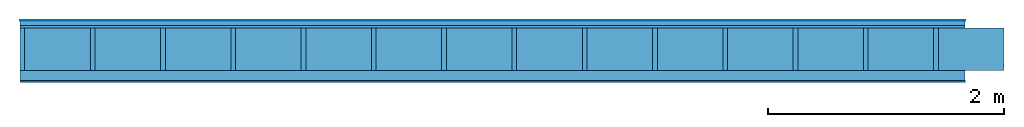
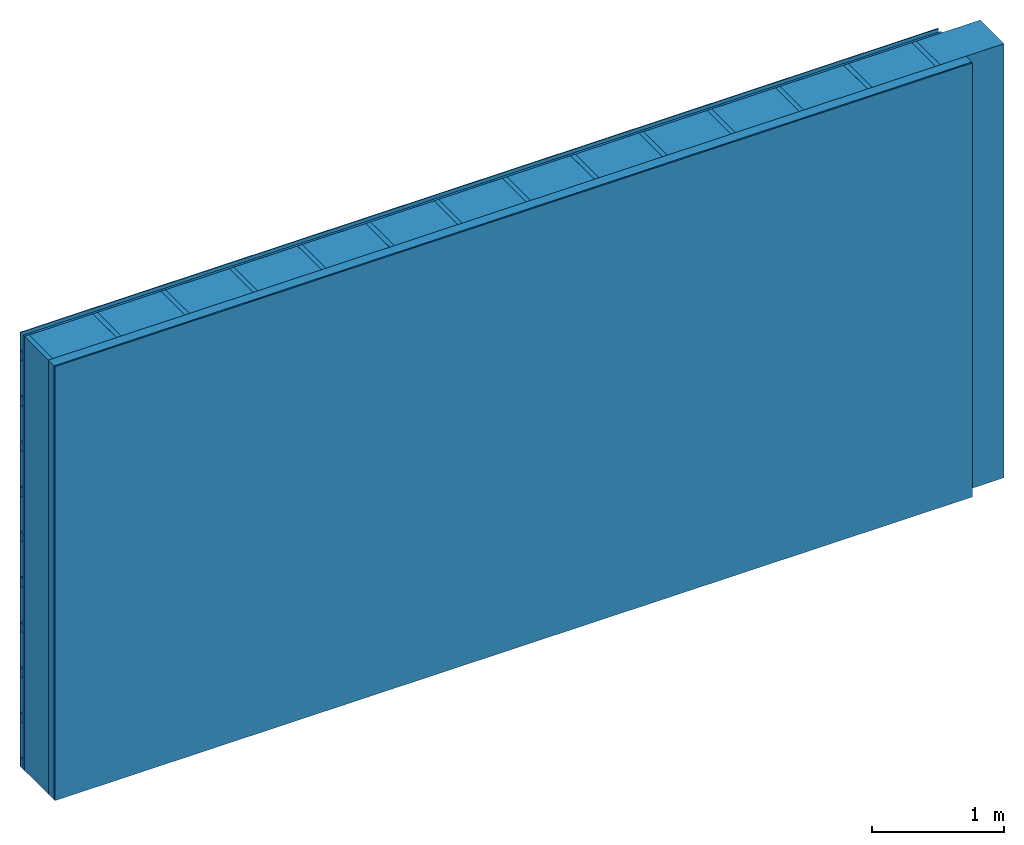
# One storey: 4 plates, 3 members, 1 element without a shape of its own.
"""IFC4 building model written with IfcOpenShell, lengths in metres."""

from ifc_helpers import new_model, si_unit, derived_unit, direction, frame, frame_2d, origin, origin_with_axes, place, context, project, spatial, rectangle, extrude, material, layer, layer_set, type_object, element, aggregate, save


model = new_model("IFC4")

# Units and contexts
plan_context = context("Plan", 3, precision=1e-05, world=origin(), true_north=direction((0.0, 1.0)))
model_context = context("Model", 3, precision=1e-05, world=origin(), true_north=direction((0.0, 1.0)))
ifc_project = project(units=[si_unit("LENGTHUNIT", "METRE"), derived_unit("SOUNDPRESSUREUNIT", [(si_unit("PRESSUREUNIT", "PASCAL", prefix="MICRO"), 0)]), si_unit("ENERGYUNIT", "JOULE", prefix="MEGA"), si_unit("MASSUNIT", "GRAM", prefix="KILO"), derived_unit("THERMALTRANSMITTANCEUNIT", [(si_unit("POWERUNIT", "WATT"), 1), (si_unit("AREAUNIT", "SQUARE_METRE"), -1), (si_unit("THERMODYNAMICTEMPERATUREUNIT", "KELVIN"), -1)]), derived_unit("AREADENSITYUNIT", [(si_unit("MASSUNIT", "GRAM", prefix="KILO"), 1), (si_unit("AREAUNIT", "SQUARE_METRE"), -1)]), derived_unit("USERDEFINED", [(si_unit("ENERGYUNIT", "JOULE", prefix="MEGA"), 1), (si_unit("AREAUNIT", "SQUARE_METRE"), -1)])], contexts=[plan_context, model_context])

# Site, building, storey
site = spatial("IfcSite", under=ifc_project)
building_placement = place(None, origin())
building = spatial("IfcBuilding", under=site, at=building_placement)
storey_placement = place(building_placement, origin())
storey = spatial("IfcBuildingStorey", under=building, at=storey_placement)

# Wall, members, plates
ifc_material_1 = material(Name="mineral, cement-based building board", Category="03.003")
ifc_layer_1 = layer(ifc_material_1, 0.008, Name="Cover 1st layer")
ifc_layer_2 = layer(None, 0.04, Name="Battens / profiles (ventilation)")
ifc_material_2 = material(Category="10.009")
ifc_layer_3 = layer(ifc_material_2, 0.02, Name="outside 1st layer")
ifc_material_3 = material(Name="of the art")
ifc_layer_4 = layer(ifc_material_3, 0.0, Name="Bond")
ifc_layer_5 = layer(None, 0.36, Name="Support")
ifc_layer_6 = layer(ifc_material_3, 0.0, Name="Bond")
ifc_material_4 = material(Name="Solid timber panel")
ifc_layer_7 = layer(ifc_material_4, 0.087, Name="1st layer")
ifc_material_5 = material(Name="Plasterboard type A", Category="03.008")
ifc_layer_8 = layer(ifc_material_5, 0.0125, Name="Covering 1st layer")
ifc_material_6 = material(Name="joints", Category="04.017")
ifc_layer_9 = layer(ifc_material_6, 0.0, Name="Surface")
ifc_layer_set = layer_set([ifc_layer_1, ifc_layer_2, ifc_layer_3, ifc_layer_4, ifc_layer_5, ifc_layer_6, ifc_layer_7, ifc_layer_8, ifc_layer_9])
wall_type = type_object("IfcWallType", Name="D0973", PredefinedType="NOTDEFINED", material=ifc_layer_set)
wall_placement = place(None, frame((0.0, 0.0, 0.0), z_axis=(0.0, -1.0, 0.0), x_axis=(1.0, 0.0, 0.0)))
wall = element("IfcWall", 1, at=wall_placement, inside=storey, type_object=wall_type, material=ifc_layer_set, Name="Wall #1")
ifc_material_7 = material()
member_1_placement = place(wall_placement, origin())
member_1 = element("IfcMember", 2, at=member_1_placement, material=ifc_material_7, Name="Battens / profiles (ventilation)", context=plan_context, shape_type="SweptSolid", body=[
    extrude(rectangle(XDim=0.08, YDim=0.04, at=frame_2d((0.04, 0.02), x_axis=(1.0, 0.0))), frame((0.0, 0.0, 0.008), z_axis=(1.0, 0.0, 0.0), x_axis=(0.0, 1.0, 0.0)), (0.0, 0.0, 1.0), 8.0),
    extrude(rectangle(XDim=0.08, YDim=0.04, at=frame_2d((0.04, 0.02), x_axis=(1.0, 0.0))), frame((0.0, 0.417, 0.008), z_axis=(1.0, 0.0, 0.0), x_axis=(0.0, 1.0, 0.0)), (0.0, 0.0, 1.0), 8.0),
    extrude(rectangle(XDim=0.08, YDim=0.04, at=frame_2d((0.04, 0.02), x_axis=(1.0, 0.0))), frame((0.0, 0.834, 0.008), z_axis=(1.0, 0.0, 0.0), x_axis=(0.0, 1.0, 0.0)), (0.0, 0.0, 1.0), 8.0),
    extrude(rectangle(XDim=0.08, YDim=0.04, at=frame_2d((0.04, 0.02), x_axis=(1.0, 0.0))), frame((0.0, 1.251, 0.008), z_axis=(1.0, 0.0, 0.0), x_axis=(0.0, 1.0, 0.0)), (0.0, 0.0, 1.0), 8.0),
    extrude(rectangle(XDim=0.08, YDim=0.04, at=frame_2d((0.04, 0.02), x_axis=(1.0, 0.0))), frame((0.0, 1.668, 0.008), z_axis=(1.0, 0.0, 0.0), x_axis=(0.0, 1.0, 0.0)), (0.0, 0.0, 1.0), 8.0),
    extrude(rectangle(XDim=0.08, YDim=0.04, at=frame_2d((0.04, 0.02), x_axis=(1.0, 0.0))), frame((0.0, 2.085, 0.008), z_axis=(1.0, 0.0, 0.0), x_axis=(0.0, 1.0, 0.0)), (0.0, 0.0, 1.0), 8.0),
    extrude(rectangle(XDim=0.08, YDim=0.04, at=frame_2d((0.04, 0.02), x_axis=(1.0, 0.0))), frame((0.0, 2.502, 0.008), z_axis=(1.0, 0.0, 0.0), x_axis=(0.0, 1.0, 0.0)), (0.0, 0.0, 1.0), 8.0),
    extrude(rectangle(XDim=0.08, YDim=0.04, at=frame_2d((0.04, 0.02), x_axis=(1.0, 0.0))), frame((0.0, 2.919, 0.008), z_axis=(1.0, 0.0, 0.0), x_axis=(0.0, 1.0, 0.0)), (0.0, 0.0, 1.0), 8.0),
    extrude(rectangle(XDim=0.08, YDim=0.04, at=frame_2d((0.04, 0.02), x_axis=(1.0, 0.0))), frame((0.0, 3.336, 0.008), z_axis=(1.0, 0.0, 0.0), x_axis=(0.0, 1.0, 0.0)), (0.0, 0.0, 1.0), 8.0),
    extrude(rectangle(XDim=0.08, YDim=0.04, at=frame_2d((0.04, 0.02), x_axis=(1.0, 0.0))), frame((0.0, 3.753, 0.008), z_axis=(1.0, 0.0, 0.0), x_axis=(0.0, 1.0, 0.0)), (0.0, 0.0, 1.0), 8.0),
])
ifc_material_8 = material()
member_2_placement = place(wall_placement, origin())
member_2 = element("IfcMember", 3, at=member_2_placement, material=ifc_material_8, Name="Support", context=plan_context, shape_type="SweptSolid", body=[
    extrude(rectangle(XDim=0.04, YDim=0.36, at=frame_2d((0.02, 0.18), x_axis=(1.0, 0.0))), frame((0.0, 4.0, 0.068), z_axis=(0.0, -1.0, 0.0), x_axis=(1.0, 0.0, 0.0)), (0.0, 0.0, 1.0), 4.0),
    extrude(rectangle(XDim=0.04, YDim=0.36, at=frame_2d((0.02, 0.18), x_axis=(1.0, 0.0))), frame((0.595, 4.0, 0.068), z_axis=(0.0, -1.0, 0.0), x_axis=(1.0, 0.0, 0.0)), (0.0, 0.0, 1.0), 4.0),
    extrude(rectangle(XDim=0.04, YDim=0.36, at=frame_2d((0.02, 0.18), x_axis=(1.0, 0.0))), frame((1.19, 4.0, 0.068), z_axis=(0.0, -1.0, 0.0), x_axis=(1.0, 0.0, 0.0)), (0.0, 0.0, 1.0), 4.0),
    extrude(rectangle(XDim=0.04, YDim=0.36, at=frame_2d((0.02, 0.18), x_axis=(1.0, 0.0))), frame((1.785, 4.0, 0.068), z_axis=(0.0, -1.0, 0.0), x_axis=(1.0, 0.0, 0.0)), (0.0, 0.0, 1.0), 4.0),
    extrude(rectangle(XDim=0.04, YDim=0.36, at=frame_2d((0.02, 0.18), x_axis=(1.0, 0.0))), frame((2.38, 4.0, 0.068), z_axis=(0.0, -1.0, 0.0), x_axis=(1.0, 0.0, 0.0)), (0.0, 0.0, 1.0), 4.0),
    extrude(rectangle(XDim=0.04, YDim=0.36, at=frame_2d((0.02, 0.18), x_axis=(1.0, 0.0))), frame((2.975, 4.0, 0.068), z_axis=(0.0, -1.0, 0.0), x_axis=(1.0, 0.0, 0.0)), (0.0, 0.0, 1.0), 4.0),
    extrude(rectangle(XDim=0.04, YDim=0.36, at=frame_2d((0.02, 0.18), x_axis=(1.0, 0.0))), frame((3.57, 4.0, 0.068), z_axis=(0.0, -1.0, 0.0), x_axis=(1.0, 0.0, 0.0)), (0.0, 0.0, 1.0), 4.0),
    extrude(rectangle(XDim=0.04, YDim=0.36, at=frame_2d((0.02, 0.18), x_axis=(1.0, 0.0))), frame((4.165, 4.0, 0.068), z_axis=(0.0, -1.0, 0.0), x_axis=(1.0, 0.0, 0.0)), (0.0, 0.0, 1.0), 4.0),
    extrude(rectangle(XDim=0.04, YDim=0.36, at=frame_2d((0.02, 0.18), x_axis=(1.0, 0.0))), frame((4.76, 4.0, 0.068), z_axis=(0.0, -1.0, 0.0), x_axis=(1.0, 0.0, 0.0)), (0.0, 0.0, 1.0), 4.0),
    extrude(rectangle(XDim=0.04, YDim=0.36, at=frame_2d((0.02, 0.18), x_axis=(1.0, 0.0))), frame((5.355, 4.0, 0.068), z_axis=(0.0, -1.0, 0.0), x_axis=(1.0, 0.0, 0.0)), (0.0, 0.0, 1.0), 4.0),
    extrude(rectangle(XDim=0.04, YDim=0.36, at=frame_2d((0.02, 0.18), x_axis=(1.0, 0.0))), frame((5.95, 4.0, 0.068), z_axis=(0.0, -1.0, 0.0), x_axis=(1.0, 0.0, 0.0)), (0.0, 0.0, 1.0), 4.0),
    extrude(rectangle(XDim=0.04, YDim=0.36, at=frame_2d((0.02, 0.18), x_axis=(1.0, 0.0))), frame((6.545, 4.0, 0.068), z_axis=(0.0, -1.0, 0.0), x_axis=(1.0, 0.0, 0.0)), (0.0, 0.0, 1.0), 4.0),
    extrude(rectangle(XDim=0.04, YDim=0.36, at=frame_2d((0.02, 0.18), x_axis=(1.0, 0.0))), frame((7.14, 4.0, 0.068), z_axis=(0.0, -1.0, 0.0), x_axis=(1.0, 0.0, 0.0)), (0.0, 0.0, 1.0), 4.0),
    extrude(rectangle(XDim=0.04, YDim=0.36, at=frame_2d((0.02, 0.18), x_axis=(1.0, 0.0))), frame((7.735, 4.0, 0.068), z_axis=(0.0, -1.0, 0.0), x_axis=(1.0, 0.0, 0.0)), (0.0, 0.0, 1.0), 4.0),
])
ifc_material_9 = material()
member_3_placement = place(wall_placement, origin())
member_3 = element("IfcMember", 4, at=member_3_placement, material=ifc_material_9, Name="Cavity", context=plan_context, shape_type="SweptSolid", body=[
    extrude(rectangle(XDim=0.555, YDim=0.36, at=frame_2d((0.2775, 0.18), x_axis=(1.0, 0.0))), frame((0.04, 4.0, 0.068), z_axis=(0.0, -1.0, 0.0), x_axis=(1.0, 0.0, 0.0)), (0.0, 0.0, 1.0), 4.0),
    extrude(rectangle(XDim=0.555, YDim=0.36, at=frame_2d((0.2775, 0.18), x_axis=(1.0, 0.0))), frame((0.635, 4.0, 0.068), z_axis=(0.0, -1.0, 0.0), x_axis=(1.0, 0.0, 0.0)), (0.0, 0.0, 1.0), 4.0),
    extrude(rectangle(XDim=0.555, YDim=0.36, at=frame_2d((0.2775, 0.18), x_axis=(1.0, 0.0))), frame((1.23, 4.0, 0.068), z_axis=(0.0, -1.0, 0.0), x_axis=(1.0, 0.0, 0.0)), (0.0, 0.0, 1.0), 4.0),
    extrude(rectangle(XDim=0.555, YDim=0.36, at=frame_2d((0.2775, 0.18), x_axis=(1.0, 0.0))), frame((1.825, 4.0, 0.068), z_axis=(0.0, -1.0, 0.0), x_axis=(1.0, 0.0, 0.0)), (0.0, 0.0, 1.0), 4.0),
    extrude(rectangle(XDim=0.555, YDim=0.36, at=frame_2d((0.2775, 0.18), x_axis=(1.0, 0.0))), frame((2.42, 4.0, 0.068), z_axis=(0.0, -1.0, 0.0), x_axis=(1.0, 0.0, 0.0)), (0.0, 0.0, 1.0), 4.0),
    extrude(rectangle(XDim=0.555, YDim=0.36, at=frame_2d((0.2775, 0.18), x_axis=(1.0, 0.0))), frame((3.015, 4.0, 0.068), z_axis=(0.0, -1.0, 0.0), x_axis=(1.0, 0.0, 0.0)), (0.0, 0.0, 1.0), 4.0),
    extrude(rectangle(XDim=0.555, YDim=0.36, at=frame_2d((0.2775, 0.18), x_axis=(1.0, 0.0))), frame((3.61, 4.0, 0.068), z_axis=(0.0, -1.0, 0.0), x_axis=(1.0, 0.0, 0.0)), (0.0, 0.0, 1.0), 4.0),
    extrude(rectangle(XDim=0.555, YDim=0.36, at=frame_2d((0.2775, 0.18), x_axis=(1.0, 0.0))), frame((4.205, 4.0, 0.068), z_axis=(0.0, -1.0, 0.0), x_axis=(1.0, 0.0, 0.0)), (0.0, 0.0, 1.0), 4.0),
    extrude(rectangle(XDim=0.555, YDim=0.36, at=frame_2d((0.2775, 0.18), x_axis=(1.0, 0.0))), frame((4.8, 4.0, 0.068), z_axis=(0.0, -1.0, 0.0), x_axis=(1.0, 0.0, 0.0)), (0.0, 0.0, 1.0), 4.0),
    extrude(rectangle(XDim=0.555, YDim=0.36, at=frame_2d((0.2775, 0.18), x_axis=(1.0, 0.0))), frame((5.395, 4.0, 0.068), z_axis=(0.0, -1.0, 0.0), x_axis=(1.0, 0.0, 0.0)), (0.0, 0.0, 1.0), 4.0),
    extrude(rectangle(XDim=0.555, YDim=0.36, at=frame_2d((0.2775, 0.18), x_axis=(1.0, 0.0))), frame((5.99, 4.0, 0.068), z_axis=(0.0, -1.0, 0.0), x_axis=(1.0, 0.0, 0.0)), (0.0, 0.0, 1.0), 4.0),
    extrude(rectangle(XDim=0.555, YDim=0.36, at=frame_2d((0.2775, 0.18), x_axis=(1.0, 0.0))), frame((6.585, 4.0, 0.068), z_axis=(0.0, -1.0, 0.0), x_axis=(1.0, 0.0, 0.0)), (0.0, 0.0, 1.0), 4.0),
    extrude(rectangle(XDim=0.555, YDim=0.36, at=frame_2d((0.2775, 0.18), x_axis=(1.0, 0.0))), frame((7.18, 4.0, 0.068), z_axis=(0.0, -1.0, 0.0), x_axis=(1.0, 0.0, 0.0)), (0.0, 0.0, 1.0), 4.0),
    extrude(rectangle(XDim=0.555, YDim=0.36, at=frame_2d((0.2775, 0.18), x_axis=(1.0, 0.0))), frame((7.775, 4.0, 0.068), z_axis=(0.0, -1.0, 0.0), x_axis=(1.0, 0.0, 0.0)), (0.0, 0.0, 1.0), 4.0),
])
plate_1_placement = place(wall_placement, origin())
plate_1 = element("IfcPlate", 5, at=plate_1_placement, material=ifc_material_1, Name="Cover 1st layer", context=plan_context, shape_type="SweptSolid", body=[
    extrude(rectangle(XDim=8.0, YDim=4.0, at=frame_2d((4.0, 2.0), x_axis=(1.0, 0.0))), origin_with_axes(), (0.0, 0.0, 1.0), 0.008),
])
plate_2_placement = place(wall_placement, origin())
plate_2 = element("IfcPlate", 6, at=plate_2_placement, material=ifc_material_2, Name="outside 1st layer", context=plan_context, shape_type="SweptSolid", body=[
    extrude(rectangle(XDim=8.0, YDim=4.0, at=frame_2d((4.0, 2.0), x_axis=(1.0, 0.0))), frame((0.0, 0.0, 0.048), z_axis=(0.0, 0.0, 1.0), x_axis=(1.0, 0.0, 0.0)), (0.0, 0.0, 1.0), 0.02),
])
plate_3_placement = place(wall_placement, origin())
plate_3 = element("IfcPlate", 7, at=plate_3_placement, material=ifc_material_4, Name="1st layer", context=plan_context, shape_type="SweptSolid", body=[
    extrude(rectangle(XDim=8.0, YDim=4.0, at=frame_2d((4.0, 2.0), x_axis=(1.0, 0.0))), frame((0.0, 0.0, 0.428), z_axis=(0.0, 0.0, 1.0), x_axis=(1.0, 0.0, 0.0)), (0.0, 0.0, 1.0), 0.087),
])
plate_4_placement = place(wall_placement, origin())
plate_4 = element("IfcPlate", 8, at=plate_4_placement, material=ifc_material_5, Name="Covering 1st layer", context=plan_context, shape_type="SweptSolid", body=[
    extrude(rectangle(XDim=8.0, YDim=4.0, at=frame_2d((4.0, 2.0), x_axis=(1.0, 0.0))), frame((0.0, 0.0, 0.515), z_axis=(0.0, 0.0, 1.0), x_axis=(1.0, 0.0, 0.0)), (0.0, 0.0, 1.0), 0.0125),
])
aggregate(wall, [plate_1, member_1, plate_2, member_2, member_3, plate_3, plate_4])

save(model, "model.ifc")
